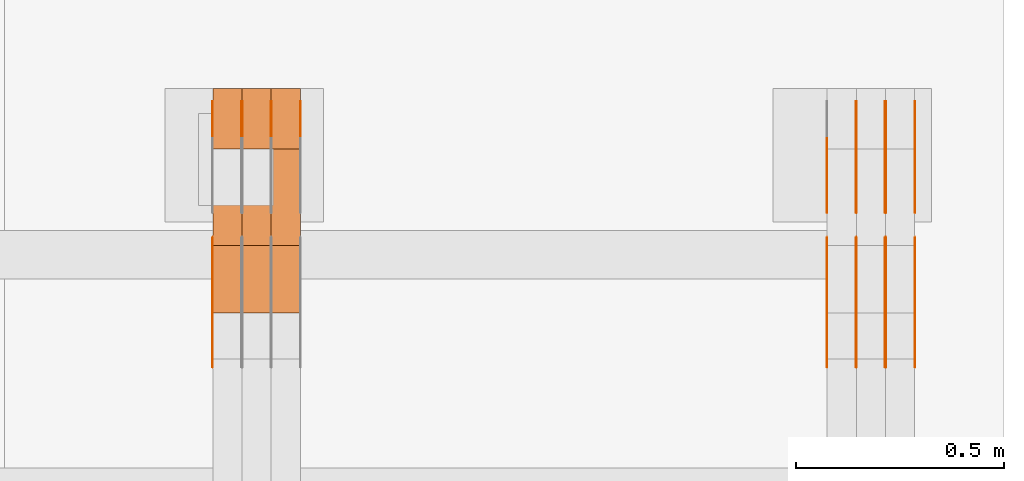
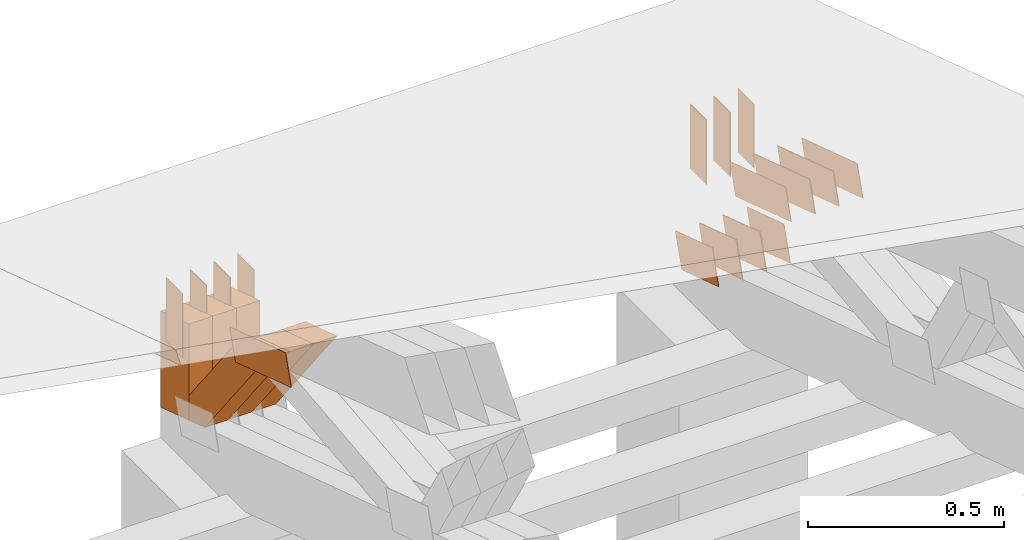
# One storey, part 376 of 385: 30 proxies.
"""IFC2X3 building model written with IfcOpenShell, lengths in millimetres."""

from ifc_helpers import new_model, entity, si_unit, converted_unit, derived_unit, direction, frame, frame_2d, origin, place, context, subcontext, project, spatial, polyline, rectangle, outline, extrude, source, transform, mapped, material, type_object, type_shapes, element, save


model = new_model("IFC2X3")

# Units and contexts
model_context = context("Model", 3, precision=0.01, world=origin(), true_north=direction((6.12303176911189e-17, 1.0)))
body_context = subcontext(model_context, "Body", "Model", "MODEL_VIEW")
ifc_project = project(units=[si_unit("LENGTHUNIT", "METRE", prefix="MILLI"), si_unit("AREAUNIT", "SQUARE_METRE"), si_unit("VOLUMEUNIT", "CUBIC_METRE"), converted_unit("PLANEANGLEUNIT", "DEGREE", entity("IfcRatioMeasure", 0.0174532925199433), si_unit("PLANEANGLEUNIT", "RADIAN"), dimensions=[0, 0, 0, 0, 0, 0, 0]), si_unit("MASSUNIT", "GRAM", prefix="KILO"), derived_unit("MASSDENSITYUNIT", [(si_unit("MASSUNIT", "GRAM", prefix="KILO"), 1), (si_unit("LENGTHUNIT", "METRE"), -3)]), si_unit("TIMEUNIT", "SECOND"), si_unit("FREQUENCYUNIT", "HERTZ"), si_unit("THERMODYNAMICTEMPERATUREUNIT", "DEGREE_CELSIUS"), derived_unit("THERMALTRANSMITTANCEUNIT", [(si_unit("MASSUNIT", "GRAM", prefix="KILO"), 1), (si_unit("THERMODYNAMICTEMPERATUREUNIT", "KELVIN"), -1), (si_unit("TIMEUNIT", "SECOND"), -3)]), derived_unit("VOLUMETRICFLOWRATEUNIT", [(si_unit("LENGTHUNIT", "METRE"), 3), (si_unit("TIMEUNIT", "SECOND"), -1)]), si_unit("ELECTRICCURRENTUNIT", "AMPERE"), si_unit("ELECTRICVOLTAGEUNIT", "VOLT"), si_unit("POWERUNIT", "WATT"), si_unit("FORCEUNIT", "NEWTON", prefix="KILO"), si_unit("ILLUMINANCEUNIT", "LUX"), si_unit("LUMINOUSFLUXUNIT", "LUMEN"), si_unit("LUMINOUSINTENSITYUNIT", "CANDELA"), derived_unit("USERDEFINED", [(si_unit("MASSUNIT", "GRAM", prefix="KILO"), -1), (si_unit("LENGTHUNIT", "METRE"), -2), (si_unit("TIMEUNIT", "SECOND"), 3), (si_unit("LUMINOUSFLUXUNIT", "LUMEN"), 1)]), derived_unit("LINEARVELOCITYUNIT", [(si_unit("LENGTHUNIT", "METRE"), 1), (si_unit("TIMEUNIT", "SECOND"), -1)]), si_unit("PRESSUREUNIT", "PASCAL"), derived_unit("USERDEFINED", [(si_unit("LENGTHUNIT", "METRE"), -2), (si_unit("MASSUNIT", "GRAM", prefix="KILO"), 1), (si_unit("TIMEUNIT", "SECOND"), -2)])], contexts=[model_context])

# Site, building, storey
site_placement = place(None, origin())
site = spatial("IfcSite", under=ifc_project, at=site_placement, CompositionType="ELEMENT")
building_placement = place(site_placement, origin())
building = spatial("IfcBuilding", under=site, at=building_placement, CompositionType="ELEMENT")
storey_placement = place(building_placement, origin())
storey = spatial("IfcBuildingStorey", under=building, at=storey_placement, Name="Default", CompositionType="ELEMENT", Elevation=0.0)

# Proxies
ifc_material_1 = material(Name="IfcSurfaceStyle #619246")
building_element_proxy_type_1 = type_object("IfcBuildingElementProxyType", PredefinedType="NOTDEFINED", material=ifc_material_1)
shared_shape_1 = source(origin(), body_context, "Body", "SweptSolid", [
    extrude(outline(polyline([(-100.000024997547, -54.0000105875654), (100.000088940899, -54.0000105875654), (99.9999100805868, 54.0000105875654), (-99.9999740239394, 54.0000105875654), (-100.000024997547, -54.0000105875654)])), frame((100.000088940899, 54.0000474633838, 0.0), z_axis=(0.0, 0.0, 1.0), x_axis=(-1.0, 0.0, 0.0)), (0.0, 0.0, 1.0), 1.3),
])
type_shapes(building_element_proxy_type_1, [shared_shape_1])
proxy_1_placement = place(building_placement, frame((49861.3, 26390.6212638563, 73.3227520411355), z_axis=(-1.0, 0.0, 0.0), x_axis=(0.0, -0.951056516295124, 0.309016994375039)))
element("IfcBuildingElementProxy", 1, at=proxy_1_placement, inside=storey, type_object=building_element_proxy_type_1, material=ifc_material_1, context=body_context, shape_type="MappedRepresentation", body=[
    mapped(shared_shape_1, transform((0.0, 0.0, 0.0), scale=1.0)),
])
ifc_material_2 = material(Name="IfcSurfaceStyle #619189")
building_element_proxy_type_2 = type_object("IfcBuildingElementProxyType", PredefinedType="NOTDEFINED", material=ifc_material_2)
shared_shape_2 = source(origin(), body_context, "Body", "SweptSolid", [
    extrude(outline(polyline([(-100.000024997547, -54.0000105875654), (100.000088940899, -54.0000105875654), (99.9999100805868, 54.0000105875654), (-99.9999740239394, 54.0000105875654), (-100.000024997547, -54.0000105875654)])), frame((100.000088940899, 54.0000474633838, 0.0), z_axis=(0.0, 0.0, 1.0), x_axis=(-1.0, 0.0, 0.0)), (0.0, 0.0, 1.0), 1.3),
])
type_shapes(building_element_proxy_type_2, [shared_shape_2])
proxy_2_placement = place(building_placement, frame((49790.0, 26390.6212638563, 73.3227520411355), z_axis=(-1.0, 0.0, 0.0), x_axis=(0.0, -0.951056516295124, 0.309016994375039)))
element("IfcBuildingElementProxy", 2, at=proxy_2_placement, inside=storey, type_object=building_element_proxy_type_2, material=ifc_material_2, context=body_context, shape_type="MappedRepresentation", body=[
    mapped(shared_shape_2, transform((0.0, 0.0, 0.0), scale=1.0)),
])
ifc_material_3 = material(Name="IfcSurfaceStyle #619132")
building_element_proxy_type_3 = type_object("IfcBuildingElementProxyType", PredefinedType="NOTDEFINED", material=ifc_material_3)
shared_shape_3 = source(origin(), body_context, "Body", "SweptSolid", [
    extrude(outline(polyline([(-100.000024997547, -54.0000105875654), (100.000088940899, -54.0000105875654), (99.9999100805868, 54.0000105875654), (-99.9999740239394, 54.0000105875654), (-100.000024997547, -54.0000105875654)])), frame((100.000088940899, 54.0000474633838, 0.0), z_axis=(0.0, 0.0, 1.0), x_axis=(-1.0, 0.0, 0.0)), (0.0, 0.0, 1.0), 1.3),
])
type_shapes(building_element_proxy_type_3, [shared_shape_3])
proxy_3_placement = place(building_placement, frame((49791.3, 26390.6212638563, 73.3227520411355), z_axis=(-1.0, 0.0, 0.0), x_axis=(0.0, -0.951056516295124, 0.309016994375039)))
element("IfcBuildingElementProxy", 3, at=proxy_3_placement, inside=storey, type_object=building_element_proxy_type_3, material=ifc_material_3, context=body_context, shape_type="MappedRepresentation", body=[
    mapped(shared_shape_3, transform((0.0, 0.0, 0.0), scale=1.0)),
])
ifc_material_4 = material(Name="IfcSurfaceStyle #619075")
building_element_proxy_type_4 = type_object("IfcBuildingElementProxyType", PredefinedType="NOTDEFINED", material=ifc_material_4)
shared_shape_4 = source(origin(), body_context, "Body", "SweptSolid", [
    extrude(outline(polyline([(-100.000024997547, -54.0000105875654), (100.000088940899, -54.0000105875654), (99.9999100805868, 54.0000105875654), (-99.9999740239394, 54.0000105875654), (-100.000024997547, -54.0000105875654)])), frame((100.000088940899, 54.0000474633838, 0.0), z_axis=(0.0, 0.0, 1.0), x_axis=(-1.0, 0.0, 0.0)), (0.0, 0.0, 1.0), 1.29999999999998),
])
type_shapes(building_element_proxy_type_4, [shared_shape_4])
proxy_4_placement = place(building_placement, frame((49720.0, 26390.6212638563, 73.3227520411355), z_axis=(-1.0, 0.0, 0.0), x_axis=(0.0, -0.951056516295124, 0.309016994375039)))
element("IfcBuildingElementProxy", 4, at=proxy_4_placement, inside=storey, type_object=building_element_proxy_type_4, material=ifc_material_4, context=body_context, shape_type="MappedRepresentation", body=[
    mapped(shared_shape_4, transform((0.0, 0.0, 0.0), scale=1.0)),
])
ifc_material_5 = material(Name="IfcSurfaceStyle #619018")
building_element_proxy_type_5 = type_object("IfcBuildingElementProxyType", PredefinedType="NOTDEFINED", material=ifc_material_5)
shared_shape_5 = source(origin(), body_context, "Body", "SweptSolid", [
    extrude(outline(polyline([(-100.000024997547, -54.0000105875654), (100.000088940899, -54.0000105875654), (99.9999100805868, 54.0000105875654), (-99.9999740239394, 54.0000105875654), (-100.000024997547, -54.0000105875654)])), frame((100.000088940899, 54.0000474633838, 0.0), z_axis=(0.0, 0.0, 1.0), x_axis=(-1.0, 0.0, 0.0)), (0.0, 0.0, 1.0), 1.29999999999998),
])
type_shapes(building_element_proxy_type_5, [shared_shape_5])
proxy_5_placement = place(building_placement, frame((49721.3, 26390.6212638563, 73.3227520411355), z_axis=(-1.0, 0.0, 0.0), x_axis=(0.0, -0.951056516295124, 0.309016994375039)))
element("IfcBuildingElementProxy", 5, at=proxy_5_placement, inside=storey, type_object=building_element_proxy_type_5, material=ifc_material_5, context=body_context, shape_type="MappedRepresentation", body=[
    mapped(shared_shape_5, transform((0.0, 0.0, 0.0), scale=1.0)),
])
ifc_material_6 = material(Name="IfcSurfaceStyle #618961")
building_element_proxy_type_6 = type_object("IfcBuildingElementProxyType", PredefinedType="NOTDEFINED", material=ifc_material_6)
shared_shape_6 = source(origin(), body_context, "Body", "SweptSolid", [
    extrude(outline(polyline([(-100.000024997547, -54.0000105875654), (100.000088940899, -54.0000105875654), (99.9999100805868, 54.0000105875654), (-99.9999740239394, 54.0000105875654), (-100.000024997547, -54.0000105875654)])), frame((100.000088940899, 54.0000474633838, 0.0), z_axis=(0.0, 0.0, 1.0), x_axis=(-1.0, 0.0, 0.0)), (0.0, 0.0, 1.0), 1.29999999999999),
])
type_shapes(building_element_proxy_type_6, [shared_shape_6])
proxy_6_placement = place(building_placement, frame((49650.0, 26390.6212638563, 73.3227520411355), z_axis=(-1.0, 0.0, 0.0), x_axis=(0.0, -0.951056516295124, 0.309016994375039)))
element("IfcBuildingElementProxy", 6, at=proxy_6_placement, inside=storey, type_object=building_element_proxy_type_6, material=ifc_material_6, context=body_context, shape_type="MappedRepresentation", body=[
    mapped(shared_shape_6, transform((0.0, 0.0, 0.0), scale=1.0)),
])
ifc_material_7 = material(Name="IfcSurfaceStyle #606592")
building_element_proxy_type_7 = type_object("IfcBuildingElementProxyType", PredefinedType="NOTDEFINED", material=ifc_material_7)
shared_shape_7 = source(origin(), body_context, "Body", "SweptSolid", [
    extrude(outline(polyline([(-149.999901061401, -48.0000057587028), (150.000035297123, -48.0000057587028), (149.999910491851, 48.0000057587028), (-150.000044727574, 48.0000057587028), (-149.999901061401, -48.0000057587028)])), frame((150.000035297123, 48.0000632585775, 0.0), z_axis=(0.0, 0.0, 1.0), x_axis=(-1.0, 0.0, 0.0)), (0.0, 0.0, 1.0), 1.29999999999999),
])
type_shapes(building_element_proxy_type_7, [shared_shape_7])
proxy_7_placement = place(building_placement, frame((49861.3, 26115.0176968219, 469.58296924555), z_axis=(-1.0, 0.0, 0.0), x_axis=(0.0, -0.951056516295154, 0.309016994374948)))
element("IfcBuildingElementProxy", 7, at=proxy_7_placement, inside=storey, type_object=building_element_proxy_type_7, material=ifc_material_7, context=body_context, shape_type="MappedRepresentation", body=[
    mapped(shared_shape_7, transform((0.0, 0.0, 0.0), scale=1.0)),
])
ifc_material_8 = material(Name="IfcSurfaceStyle #606535")
building_element_proxy_type_8 = type_object("IfcBuildingElementProxyType", PredefinedType="NOTDEFINED", material=ifc_material_8)
shared_shape_8 = source(origin(), body_context, "Body", "SweptSolid", [
    extrude(outline(polyline([(-149.999901061401, -48.0000057587028), (150.000035297123, -48.0000057587028), (149.999910491851, 48.0000057587028), (-150.000044727574, 48.0000057587028), (-149.999901061401, -48.0000057587028)])), frame((150.000035297123, 48.0000632585775, 0.0), z_axis=(0.0, 0.0, 1.0), x_axis=(-1.0, 0.0, 0.0)), (0.0, 0.0, 1.0), 1.29999999999999),
])
type_shapes(building_element_proxy_type_8, [shared_shape_8])
proxy_8_placement = place(building_placement, frame((49790.0, 26115.0176968219, 469.58296924555), z_axis=(-1.0, 0.0, 0.0), x_axis=(0.0, -0.951056516295154, 0.309016994374948)))
element("IfcBuildingElementProxy", 8, at=proxy_8_placement, inside=storey, type_object=building_element_proxy_type_8, material=ifc_material_8, context=body_context, shape_type="MappedRepresentation", body=[
    mapped(shared_shape_8, transform((0.0, 0.0, 0.0), scale=1.0)),
])
ifc_material_9 = material(Name="IfcSurfaceStyle #606478")
building_element_proxy_type_9 = type_object("IfcBuildingElementProxyType", PredefinedType="NOTDEFINED", material=ifc_material_9)
shared_shape_9 = source(origin(), body_context, "Body", "SweptSolid", [
    extrude(outline(polyline([(-149.999901061401, -48.0000057587028), (150.000035297123, -48.0000057587028), (149.999910491851, 48.0000057587028), (-150.000044727574, 48.0000057587028), (-149.999901061401, -48.0000057587028)])), frame((150.000035297123, 48.0000632585775, 0.0), z_axis=(0.0, 0.0, 1.0), x_axis=(-1.0, 0.0, 0.0)), (0.0, 0.0, 1.0), 1.29999999999999),
])
type_shapes(building_element_proxy_type_9, [shared_shape_9])
proxy_9_placement = place(building_placement, frame((49791.3, 26115.0176968219, 469.58296924555), z_axis=(-1.0, 0.0, 0.0), x_axis=(0.0, -0.951056516295154, 0.309016994374948)))
element("IfcBuildingElementProxy", 9, at=proxy_9_placement, inside=storey, type_object=building_element_proxy_type_9, material=ifc_material_9, context=body_context, shape_type="MappedRepresentation", body=[
    mapped(shared_shape_9, transform((0.0, 0.0, 0.0), scale=1.0)),
])
ifc_material_10 = material(Name="IfcSurfaceStyle #606421")
building_element_proxy_type_10 = type_object("IfcBuildingElementProxyType", PredefinedType="NOTDEFINED", material=ifc_material_10)
shared_shape_10 = source(origin(), body_context, "Body", "SweptSolid", [
    extrude(outline(polyline([(-149.999901061401, -48.0000057587028), (150.000035297123, -48.0000057587028), (149.999910491851, 48.0000057587028), (-150.000044727574, 48.0000057587028), (-149.999901061401, -48.0000057587028)])), frame((150.000035297123, 48.0000632585775, 0.0), z_axis=(0.0, 0.0, 1.0), x_axis=(-1.0, 0.0, 0.0)), (0.0, 0.0, 1.0), 1.29999999999998),
])
type_shapes(building_element_proxy_type_10, [shared_shape_10])
proxy_10_placement = place(building_placement, frame((49720.0, 26115.0176968219, 469.58296924555), z_axis=(-1.0, 0.0, 0.0), x_axis=(0.0, -0.951056516295154, 0.309016994374948)))
element("IfcBuildingElementProxy", 10, at=proxy_10_placement, inside=storey, type_object=building_element_proxy_type_10, material=ifc_material_10, context=body_context, shape_type="MappedRepresentation", body=[
    mapped(shared_shape_10, transform((0.0, 0.0, 0.0), scale=1.0)),
])
ifc_material_11 = material(Name="IfcSurfaceStyle #606364")
building_element_proxy_type_11 = type_object("IfcBuildingElementProxyType", PredefinedType="NOTDEFINED", material=ifc_material_11)
shared_shape_11 = source(origin(), body_context, "Body", "SweptSolid", [
    extrude(outline(polyline([(-149.999901061401, -48.0000057587028), (150.000035297123, -48.0000057587028), (149.999910491851, 48.0000057587028), (-150.000044727574, 48.0000057587028), (-149.999901061401, -48.0000057587028)])), frame((150.000035297123, 48.0000632585775, 0.0), z_axis=(0.0, 0.0, 1.0), x_axis=(-1.0, 0.0, 0.0)), (0.0, 0.0, 1.0), 1.29999999999998),
])
type_shapes(building_element_proxy_type_11, [shared_shape_11])
proxy_11_placement = place(building_placement, frame((49721.3, 26115.0176968219, 469.58296924555), z_axis=(-1.0, 0.0, 0.0), x_axis=(0.0, -0.951056516295154, 0.309016994374948)))
element("IfcBuildingElementProxy", 11, at=proxy_11_placement, inside=storey, type_object=building_element_proxy_type_11, material=ifc_material_11, context=body_context, shape_type="MappedRepresentation", body=[
    mapped(shared_shape_11, transform((0.0, 0.0, 0.0), scale=1.0)),
])
ifc_material_12 = material(Name="IfcSurfaceStyle #606307")
building_element_proxy_type_12 = type_object("IfcBuildingElementProxyType", PredefinedType="NOTDEFINED", material=ifc_material_12)
shared_shape_12 = source(origin(), body_context, "Body", "SweptSolid", [
    extrude(outline(polyline([(-149.999901061401, -48.0000057587028), (150.000035297123, -48.0000057587028), (149.999910491851, 48.0000057587028), (-150.000044727574, 48.0000057587028), (-149.999901061401, -48.0000057587028)])), frame((150.000035297123, 48.0000632585775, 0.0), z_axis=(0.0, 0.0, 1.0), x_axis=(-1.0, 0.0, 0.0)), (0.0, 0.0, 1.0), 1.29999999999998),
])
type_shapes(building_element_proxy_type_12, [shared_shape_12])
proxy_12_placement = place(building_placement, frame((49650.0, 26115.0176968219, 469.58296924555), z_axis=(-1.0, 0.0, 0.0), x_axis=(0.0, -0.951056516295154, 0.309016994374948)))
element("IfcBuildingElementProxy", 12, at=proxy_12_placement, inside=storey, type_object=building_element_proxy_type_12, material=ifc_material_12, context=body_context, shape_type="MappedRepresentation", body=[
    mapped(shared_shape_12, transform((0.0, 0.0, 0.0), scale=1.0)),
])
ifc_material_13 = material(Name="IfcSurfaceStyle #606250")
building_element_proxy_type_13 = type_object("IfcBuildingElementProxyType", PredefinedType="NOTDEFINED", material=ifc_material_13)
shared_shape_13 = source(origin(), body_context, "Body", "SweptSolid", [
    extrude(rectangle(XDim=200.0, YDim=84.0000000000005, at=frame_2d((-2.1316282072803e-14, 1.06581410364015e-14), x_axis=(1.0, 0.0))), frame((100.0, 42.0, 0.0), z_axis=(0.0, 0.0, 1.0), x_axis=(-1.0, 0.0, 0.0)), (0.0, 0.0, 1.0), 1.3),
])
type_shapes(building_element_proxy_type_13, [shared_shape_13])
proxy_13_placement = place(building_placement, frame((49861.3, 26469.5000000002, 518.521545410156), z_axis=(-1.0, 0.0, 0.0), x_axis=(0.0, 0.0, -1.0)))
element("IfcBuildingElementProxy", 13, at=proxy_13_placement, inside=storey, type_object=building_element_proxy_type_13, material=ifc_material_13, context=body_context, shape_type="MappedRepresentation", body=[
    mapped(shared_shape_13, transform((0.0, 0.0, 0.0), scale=1.0)),
])
ifc_material_14 = material(Name="IfcSurfaceStyle #606193")
building_element_proxy_type_14 = type_object("IfcBuildingElementProxyType", PredefinedType="NOTDEFINED", material=ifc_material_14)
shared_shape_14 = source(origin(), body_context, "Body", "SweptSolid", [
    extrude(rectangle(XDim=200.0, YDim=84.0000000000005, at=frame_2d((-2.1316282072803e-14, 1.06581410364015e-14), x_axis=(1.0, 0.0))), frame((100.0, 42.0, 0.0), z_axis=(0.0, 0.0, 1.0), x_axis=(-1.0, 0.0, 0.0)), (0.0, 0.0, 1.0), 1.3),
])
type_shapes(building_element_proxy_type_14, [shared_shape_14])
proxy_14_placement = place(building_placement, frame((49790.0, 26469.5000000002, 518.521545410156), z_axis=(-1.0, 0.0, 0.0), x_axis=(0.0, 0.0, -1.0)))
element("IfcBuildingElementProxy", 14, at=proxy_14_placement, inside=storey, type_object=building_element_proxy_type_14, material=ifc_material_14, context=body_context, shape_type="MappedRepresentation", body=[
    mapped(shared_shape_14, transform((0.0, 0.0, 0.0), scale=1.0)),
])
ifc_material_15 = material(Name="IfcSurfaceStyle #606136")
building_element_proxy_type_15 = type_object("IfcBuildingElementProxyType", PredefinedType="NOTDEFINED", material=ifc_material_15)
shared_shape_15 = source(origin(), body_context, "Body", "SweptSolid", [
    extrude(rectangle(XDim=200.0, YDim=84.0000000000005, at=frame_2d((-2.1316282072803e-14, 1.06581410364015e-14), x_axis=(1.0, 0.0))), frame((100.0, 42.0, 0.0), z_axis=(0.0, 0.0, 1.0), x_axis=(-1.0, 0.0, 0.0)), (0.0, 0.0, 1.0), 1.3),
])
type_shapes(building_element_proxy_type_15, [shared_shape_15])
proxy_15_placement = place(building_placement, frame((49791.3, 26469.5000000002, 518.521545410156), z_axis=(-1.0, 0.0, 0.0), x_axis=(0.0, 0.0, -1.0)))
element("IfcBuildingElementProxy", 15, at=proxy_15_placement, inside=storey, type_object=building_element_proxy_type_15, material=ifc_material_15, context=body_context, shape_type="MappedRepresentation", body=[
    mapped(shared_shape_15, transform((0.0, 0.0, 0.0), scale=1.0)),
])
ifc_material_16 = material(Name="IfcSurfaceStyle #606079")
building_element_proxy_type_16 = type_object("IfcBuildingElementProxyType", PredefinedType="NOTDEFINED", material=ifc_material_16)
shared_shape_16 = source(origin(), body_context, "Body", "SweptSolid", [
    extrude(rectangle(XDim=200.0, YDim=84.0000000000005, at=frame_2d((-2.1316282072803e-14, 1.06581410364015e-14), x_axis=(1.0, 0.0))), frame((100.0, 42.0, 0.0), z_axis=(0.0, 0.0, 1.0), x_axis=(-1.0, 0.0, 0.0)), (0.0, 0.0, 1.0), 1.29999999999998),
])
type_shapes(building_element_proxy_type_16, [shared_shape_16])
proxy_16_placement = place(building_placement, frame((49720.0, 26469.5000000002, 518.521545410156), z_axis=(-1.0, 0.0, 0.0), x_axis=(0.0, 0.0, -1.0)))
element("IfcBuildingElementProxy", 16, at=proxy_16_placement, inside=storey, type_object=building_element_proxy_type_16, material=ifc_material_16, context=body_context, shape_type="MappedRepresentation", body=[
    mapped(shared_shape_16, transform((0.0, 0.0, 0.0), scale=1.0)),
])
ifc_material_17 = material(Name="IfcSurfaceStyle #606022")
building_element_proxy_type_17 = type_object("IfcBuildingElementProxyType", PredefinedType="NOTDEFINED", material=ifc_material_17)
shared_shape_17 = source(origin(), body_context, "Body", "SweptSolid", [
    extrude(rectangle(XDim=200.0, YDim=84.0000000000005, at=frame_2d((-2.1316282072803e-14, 1.06581410364015e-14), x_axis=(1.0, 0.0))), frame((100.0, 42.0, 0.0), z_axis=(0.0, 0.0, 1.0), x_axis=(-1.0, 0.0, 0.0)), (0.0, 0.0, 1.0), 1.29999999999998),
])
type_shapes(building_element_proxy_type_17, [shared_shape_17])
proxy_17_placement = place(building_placement, frame((49721.3, 26469.5000000002, 518.521545410156), z_axis=(-1.0, 0.0, 0.0), x_axis=(0.0, 0.0, -1.0)))
element("IfcBuildingElementProxy", 17, at=proxy_17_placement, inside=storey, type_object=building_element_proxy_type_17, material=ifc_material_17, context=body_context, shape_type="MappedRepresentation", body=[
    mapped(shared_shape_17, transform((0.0, 0.0, 0.0), scale=1.0)),
])
ifc_material_18 = material(Name="IfcSurfaceStyle #571875")
building_element_proxy_type_18 = type_object("IfcBuildingElementProxyType", PredefinedType="NOTDEFINED", material=ifc_material_18)
shared_shape_18 = source(origin(), body_context, "Body", "SweptSolid", [
    extrude(outline(polyline([(-149.999901061401, -48.0000057587028), (150.000035297123, -48.0000057587028), (149.999910491851, 48.0000057587028), (-150.000044727574, 48.0000057587028), (-149.999901061401, -48.0000057587028)])), frame((150.000035297123, 48.0000632585775, 0.0), z_axis=(0.0, 0.0, 1.0), x_axis=(-1.0, 0.0, 0.0)), (0.0, 0.0, 1.0), 1.29999999999998),
])
type_shapes(building_element_proxy_type_18, [shared_shape_18])
proxy_18_placement = place(building_placement, frame((48175.0, 26115.0176968219, 469.58296924555), z_axis=(-1.0, 0.0, 0.0), x_axis=(0.0, -0.951056516295154, 0.309016994374948)))
element("IfcBuildingElementProxy", 18, at=proxy_18_placement, inside=storey, type_object=building_element_proxy_type_18, material=ifc_material_18, context=body_context, shape_type="MappedRepresentation", body=[
    mapped(shared_shape_18, transform((0.0, 0.0, 0.0), scale=1.0)),
])
ifc_material_19 = material(Name="IfcSurfaceStyle #571818")
building_element_proxy_type_19 = type_object("IfcBuildingElementProxyType", PredefinedType="NOTDEFINED", material=ifc_material_19)
shared_shape_19 = source(origin(), body_context, "Body", "SweptSolid", [
    extrude(rectangle(XDim=200.0, YDim=84.0000000000005, at=frame_2d((-2.1316282072803e-14, 1.06581410364015e-14), x_axis=(1.0, 0.0))), frame((100.0, 42.0, 0.0), z_axis=(0.0, 0.0, 1.0), x_axis=(-1.0, 0.0, 0.0)), (0.0, 0.0, 1.0), 1.3),
])
type_shapes(building_element_proxy_type_19, [shared_shape_19])
proxy_19_placement = place(building_placement, frame((48386.3, 26469.5000000002, 518.521545410156), z_axis=(-1.0, 0.0, 0.0), x_axis=(0.0, 0.0, -1.0)))
element("IfcBuildingElementProxy", 19, at=proxy_19_placement, inside=storey, type_object=building_element_proxy_type_19, material=ifc_material_19, context=body_context, shape_type="MappedRepresentation", body=[
    mapped(shared_shape_19, transform((0.0, 0.0, 0.0), scale=1.0)),
])
ifc_material_20 = material(Name="IfcSurfaceStyle #571761")
building_element_proxy_type_20 = type_object("IfcBuildingElementProxyType", PredefinedType="NOTDEFINED", material=ifc_material_20)
shared_shape_20 = source(origin(), body_context, "Body", "SweptSolid", [
    extrude(rectangle(XDim=200.0, YDim=84.0000000000005, at=frame_2d((-2.1316282072803e-14, 1.06581410364015e-14), x_axis=(1.0, 0.0))), frame((100.0, 42.0, 0.0), z_axis=(0.0, 0.0, 1.0), x_axis=(-1.0, 0.0, 0.0)), (0.0, 0.0, 1.0), 1.3),
])
type_shapes(building_element_proxy_type_20, [shared_shape_20])
proxy_20_placement = place(building_placement, frame((48315.0, 26469.5000000002, 518.521545410156), z_axis=(-1.0, 0.0, 0.0), x_axis=(0.0, 0.0, -1.0)))
element("IfcBuildingElementProxy", 20, at=proxy_20_placement, inside=storey, type_object=building_element_proxy_type_20, material=ifc_material_20, context=body_context, shape_type="MappedRepresentation", body=[
    mapped(shared_shape_20, transform((0.0, 0.0, 0.0), scale=1.0)),
])
ifc_material_21 = material(Name="IfcSurfaceStyle #571704")
building_element_proxy_type_21 = type_object("IfcBuildingElementProxyType", PredefinedType="NOTDEFINED", material=ifc_material_21)
shared_shape_21 = source(origin(), body_context, "Body", "SweptSolid", [
    extrude(rectangle(XDim=200.0, YDim=84.0000000000005, at=frame_2d((-2.1316282072803e-14, 1.06581410364015e-14), x_axis=(1.0, 0.0))), frame((100.0, 42.0, 0.0), z_axis=(0.0, 0.0, 1.0), x_axis=(-1.0, 0.0, 0.0)), (0.0, 0.0, 1.0), 1.3),
])
type_shapes(building_element_proxy_type_21, [shared_shape_21])
proxy_21_placement = place(building_placement, frame((48316.3, 26469.5000000002, 518.521545410156), z_axis=(-1.0, 0.0, 0.0), x_axis=(0.0, 0.0, -1.0)))
element("IfcBuildingElementProxy", 21, at=proxy_21_placement, inside=storey, type_object=building_element_proxy_type_21, material=ifc_material_21, context=body_context, shape_type="MappedRepresentation", body=[
    mapped(shared_shape_21, transform((0.0, 0.0, 0.0), scale=1.0)),
])
ifc_material_22 = material(Name="IfcSurfaceStyle #571647")
building_element_proxy_type_22 = type_object("IfcBuildingElementProxyType", PredefinedType="NOTDEFINED", material=ifc_material_22)
shared_shape_22 = source(origin(), body_context, "Body", "SweptSolid", [
    extrude(rectangle(XDim=200.0, YDim=84.0000000000005, at=frame_2d((-2.1316282072803e-14, 1.06581410364015e-14), x_axis=(1.0, 0.0))), frame((100.0, 42.0, 0.0), z_axis=(0.0, 0.0, 1.0), x_axis=(-1.0, 0.0, 0.0)), (0.0, 0.0, 1.0), 1.29999999999998),
])
type_shapes(building_element_proxy_type_22, [shared_shape_22])
proxy_22_placement = place(building_placement, frame((48245.0, 26469.5000000002, 518.521545410156), z_axis=(-1.0, 0.0, 0.0), x_axis=(0.0, 0.0, -1.0)))
element("IfcBuildingElementProxy", 22, at=proxy_22_placement, inside=storey, type_object=building_element_proxy_type_22, material=ifc_material_22, context=body_context, shape_type="MappedRepresentation", body=[
    mapped(shared_shape_22, transform((0.0, 0.0, 0.0), scale=1.0)),
])
ifc_material_23 = material(Name="IfcSurfaceStyle #571590")
building_element_proxy_type_23 = type_object("IfcBuildingElementProxyType", PredefinedType="NOTDEFINED", material=ifc_material_23)
shared_shape_23 = source(origin(), body_context, "Body", "SweptSolid", [
    extrude(rectangle(XDim=200.0, YDim=84.0000000000005, at=frame_2d((-2.1316282072803e-14, 1.06581410364015e-14), x_axis=(1.0, 0.0))), frame((100.0, 42.0, 0.0), z_axis=(0.0, 0.0, 1.0), x_axis=(-1.0, 0.0, 0.0)), (0.0, 0.0, 1.0), 1.29999999999998),
])
type_shapes(building_element_proxy_type_23, [shared_shape_23])
proxy_23_placement = place(building_placement, frame((48246.3, 26469.5000000002, 518.521545410156), z_axis=(-1.0, 0.0, 0.0), x_axis=(0.0, 0.0, -1.0)))
element("IfcBuildingElementProxy", 23, at=proxy_23_placement, inside=storey, type_object=building_element_proxy_type_23, material=ifc_material_23, context=body_context, shape_type="MappedRepresentation", body=[
    mapped(shared_shape_23, transform((0.0, 0.0, 0.0), scale=1.0)),
])
ifc_material_24 = material(Name="IfcSurfaceStyle #571533")
building_element_proxy_type_24 = type_object("IfcBuildingElementProxyType", PredefinedType="NOTDEFINED", material=ifc_material_24)
shared_shape_24 = source(origin(), body_context, "Body", "SweptSolid", [
    extrude(rectangle(XDim=200.0, YDim=84.0000000000005, at=frame_2d((-2.1316282072803e-14, 1.06581410364015e-14), x_axis=(1.0, 0.0))), frame((100.0, 42.0, 0.0), z_axis=(0.0, 0.0, 1.0), x_axis=(-1.0, 0.0, 0.0)), (0.0, 0.0, 1.0), 1.29999999999999),
])
type_shapes(building_element_proxy_type_24, [shared_shape_24])
proxy_24_placement = place(building_placement, frame((48175.0, 26469.5000000002, 518.521545410156), z_axis=(-1.0, 0.0, 0.0), x_axis=(0.0, 0.0, -1.0)))
element("IfcBuildingElementProxy", 24, at=proxy_24_placement, inside=storey, type_object=building_element_proxy_type_24, material=ifc_material_24, context=body_context, shape_type="MappedRepresentation", body=[
    mapped(shared_shape_24, transform((0.0, 0.0, 0.0), scale=1.0)),
])
ifc_material_25 = material(Name="IfcSurfaceStyle #560010")
building_element_proxy_type_25 = type_object("IfcBuildingElementProxyType", Name="T1-W21 560008", PredefinedType="NOTDEFINED", material=ifc_material_25)
shared_shape_25 = source(origin(), body_context, "Body", "SweptSolid", [
    extrude(outline(polyline([(-209.199362597501, -47.5000308982766), (168.813164734153, -47.5000308982766), (229.900717355638, -2.18385470334148e-05), (159.828709317766, 47.5000418175501), (-349.343228810055, 47.5000418175502), (-209.199362597501, -47.5000308982766)])), frame((229.900720156071, 47.5000418175501, 0.0), z_axis=(0.0, 0.0, 1.0), x_axis=(-1.0, 0.0, 0.0)), (0.0, 0.0, 1.0), 70.0),
])
type_shapes(building_element_proxy_type_25, [shared_shape_25])
proxy_25_placement = place(building_placement, frame((48385.0, 26317.5019908272, 112.518372832984), z_axis=(-1.0, 0.0, 0.0), x_axis=(0.0, -0.613839629272042, 0.789430750310097)))
element("IfcBuildingElementProxy", 25, at=proxy_25_placement, inside=storey, type_object=building_element_proxy_type_25, material=ifc_material_25, Name="T1-W21", context=body_context, shape_type="MappedRepresentation", body=[
    mapped(shared_shape_25, transform((0.0, 0.0, 0.0), scale=1.0)),
])
ifc_material_26 = material(Name="IfcSurfaceStyle #559944")
building_element_proxy_type_26 = type_object("IfcBuildingElementProxyType", Name="T1-W21 559942", PredefinedType="NOTDEFINED", material=ifc_material_26)
shared_shape_26 = source(origin(), body_context, "Body", "SweptSolid", [
    extrude(outline(polyline([(-209.199362597501, -47.5000308982766), (168.813164734153, -47.5000308982766), (229.900717355638, -2.18385470334148e-05), (159.828709317766, 47.5000418175501), (-349.343228810055, 47.5000418175502), (-209.199362597501, -47.5000308982766)])), frame((229.900720156071, 47.5000418175501, 0.0), z_axis=(0.0, 0.0, 1.0), x_axis=(-1.0, 0.0, 0.0)), (0.0, 0.0, 1.0), 70.0),
])
type_shapes(building_element_proxy_type_26, [shared_shape_26])
proxy_26_placement = place(building_placement, frame((48315.0, 26317.5019908272, 112.518372832984), z_axis=(-1.0, 0.0, 0.0), x_axis=(0.0, -0.613839629272042, 0.789430750310097)))
element("IfcBuildingElementProxy", 26, at=proxy_26_placement, inside=storey, type_object=building_element_proxy_type_26, material=ifc_material_26, Name="T1-W21", context=body_context, shape_type="MappedRepresentation", body=[
    mapped(shared_shape_26, transform((0.0, 0.0, 0.0), scale=1.0)),
])
ifc_material_27 = material(Name="IfcSurfaceStyle #559878")
building_element_proxy_type_27 = type_object("IfcBuildingElementProxyType", Name="T1-W21 559876", PredefinedType="NOTDEFINED", material=ifc_material_27)
shared_shape_27 = source(origin(), body_context, "Body", "SweptSolid", [
    extrude(outline(polyline([(-209.199362597501, -47.5000308982766), (168.813164734153, -47.5000308982766), (229.900717355638, -2.18385470334148e-05), (159.828709317766, 47.5000418175501), (-349.343228810055, 47.5000418175502), (-209.199362597501, -47.5000308982766)])), frame((229.900720156071, 47.5000418175501, 0.0), z_axis=(0.0, 0.0, 1.0), x_axis=(-1.0, 0.0, 0.0)), (0.0, 0.0, 1.0), 70.0),
])
type_shapes(building_element_proxy_type_27, [shared_shape_27])
proxy_27_placement = place(building_placement, frame((48245.0, 26317.5019908272, 112.518372832984), z_axis=(-1.0, 0.0, 0.0), x_axis=(0.0, -0.613839629272042, 0.789430750310097)))
element("IfcBuildingElementProxy", 27, at=proxy_27_placement, inside=storey, type_object=building_element_proxy_type_27, material=ifc_material_27, Name="T1-W21", context=body_context, shape_type="MappedRepresentation", body=[
    mapped(shared_shape_27, transform((0.0, 0.0, 0.0), scale=1.0)),
])
ifc_material_28 = material(Name="IfcSurfaceStyle #559443")
building_element_proxy_type_28 = type_object("IfcBuildingElementProxyType", Name="T1-E2 559441", PredefinedType="NOTDEFINED", material=ifc_material_28)
shared_shape_28 = source(origin(), body_context, "Body", "SweptSolid", [
    extrude(outline(polyline([(-126.644535064697, -72.4999999999998), (173.757884979248, -72.4999999999998), (126.644542694092, 72.4999999999998), (-173.757892608642, 72.4999999999998), (-126.644535064697, -72.4999999999998)])), frame((173.757890653796, 72.5000000000002, 0.0), z_axis=(0.0, 0.0, 1.0), x_axis=(-1.0, 0.0, 0.0)), (0.0, 0.0, 1.0), 70.0),
])
type_shapes(building_element_proxy_type_28, [shared_shape_28])
proxy_28_placement = place(building_placement, frame((48385.0, 26500.0, 442.078222227283), z_axis=(-1.0, 0.0, 0.0), x_axis=(0.0, 0.0, -1.0)))
element("IfcBuildingElementProxy", 28, at=proxy_28_placement, inside=storey, type_object=building_element_proxy_type_28, material=ifc_material_28, Name="T1-E2", context=body_context, shape_type="MappedRepresentation", body=[
    mapped(shared_shape_28, transform((0.0, 0.0, 0.0), scale=1.0)),
])
ifc_material_29 = material(Name="IfcSurfaceStyle #559386")
building_element_proxy_type_29 = type_object("IfcBuildingElementProxyType", Name="T1-E2 559384", PredefinedType="NOTDEFINED", material=ifc_material_29)
shared_shape_29 = source(origin(), body_context, "Body", "SweptSolid", [
    extrude(outline(polyline([(-126.644535064697, -72.4999999999998), (173.757884979248, -72.4999999999998), (126.644542694092, 72.4999999999998), (-173.757892608642, 72.4999999999998), (-126.644535064697, -72.4999999999998)])), frame((173.757890653796, 72.5000000000002, 0.0), z_axis=(0.0, 0.0, 1.0), x_axis=(-1.0, 0.0, 0.0)), (0.0, 0.0, 1.0), 70.0),
])
type_shapes(building_element_proxy_type_29, [shared_shape_29])
proxy_29_placement = place(building_placement, frame((48315.0, 26500.0, 442.078222227283), z_axis=(-1.0, 0.0, 0.0), x_axis=(0.0, 0.0, -1.0)))
element("IfcBuildingElementProxy", 29, at=proxy_29_placement, inside=storey, type_object=building_element_proxy_type_29, material=ifc_material_29, Name="T1-E2", context=body_context, shape_type="MappedRepresentation", body=[
    mapped(shared_shape_29, transform((0.0, 0.0, 0.0), scale=1.0)),
])
ifc_material_30 = material(Name="IfcSurfaceStyle #559329")
building_element_proxy_type_30 = type_object("IfcBuildingElementProxyType", Name="T1-E2 559327", PredefinedType="NOTDEFINED", material=ifc_material_30)
shared_shape_30 = source(origin(), body_context, "Body", "SweptSolid", [
    extrude(outline(polyline([(-126.644535064697, -72.4999999999998), (173.757884979248, -72.4999999999998), (126.644542694092, 72.4999999999998), (-173.757892608642, 72.4999999999998), (-126.644535064697, -72.4999999999998)])), frame((173.757890653796, 72.5000000000002, 0.0), z_axis=(0.0, 0.0, 1.0), x_axis=(-1.0, 0.0, 0.0)), (0.0, 0.0, 1.0), 70.0),
])
type_shapes(building_element_proxy_type_30, [shared_shape_30])
proxy_30_placement = place(building_placement, frame((48245.0, 26500.0, 442.078222227283), z_axis=(-1.0, 0.0, 0.0), x_axis=(0.0, 0.0, -1.0)))
element("IfcBuildingElementProxy", 30, at=proxy_30_placement, inside=storey, type_object=building_element_proxy_type_30, material=ifc_material_30, Name="T1-E2", context=body_context, shape_type="MappedRepresentation", body=[
    mapped(shared_shape_30, transform((0.0, 0.0, 0.0), scale=1.0)),
])

save(model, "model.ifc")
